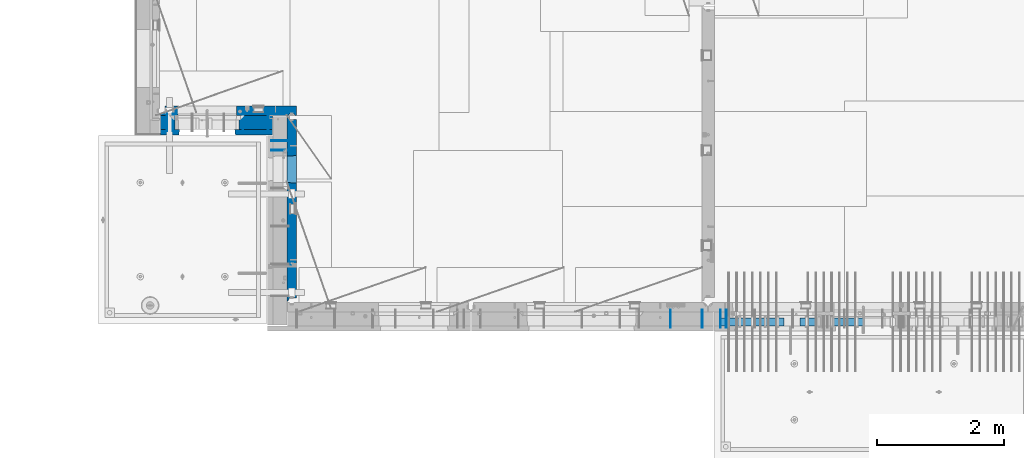
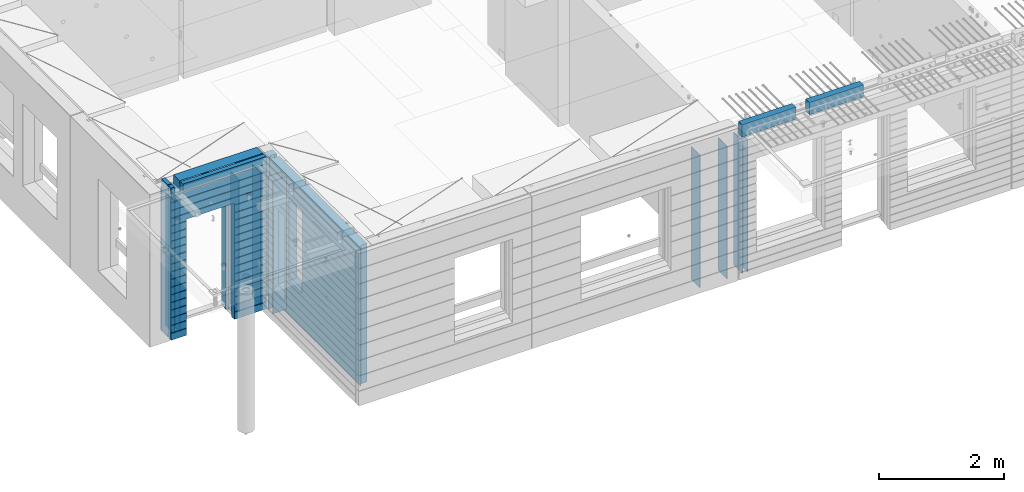
# One storey, part 228 of 349: 16 walls, 7 elements without a shape of their own.
"""IFC2X3 building model written with IfcOpenShell, lengths in millimetres."""

from ifc_helpers import new_model, si_unit, frame, origin_with_axes, place, context, subcontext, project, spatial, faceted_brep, material, type_object, element, aggregate, save


model = new_model("IFC2X3")

# Units and contexts
model_context = context("Model", 3, precision=1e-05, world=origin_with_axes())
body_context = subcontext(model_context, "Body", "Model", "MODEL_VIEW")
ifc_project = project(units=[si_unit("LENGTHUNIT", "METRE", prefix="MILLI"), si_unit("AREAUNIT", "SQUARE_METRE"), si_unit("VOLUMEUNIT", "CUBIC_METRE"), si_unit("MASSUNIT", "GRAM", prefix="KILO"), si_unit("TIMEUNIT", "SECOND"), si_unit("PLANEANGLEUNIT", "RADIAN"), si_unit("SOLIDANGLEUNIT", "STERADIAN"), si_unit("THERMODYNAMICTEMPERATUREUNIT", "DEGREE_CELSIUS"), si_unit("LUMINOUSINTENSITYUNIT", "LUMEN")], contexts=[model_context])

# Site, building, storey
site_placement = place(None, origin_with_axes())
site = spatial("IfcSite", under=ifc_project, at=site_placement, CompositionType="ELEMENT")
building_placement = place(site_placement, origin_with_axes())
building = spatial("IfcBuilding", under=site, at=building_placement, CompositionType="ELEMENT")
storey_placement = place(building_placement, origin_with_axes())
storey = spatial("IfcBuildingStorey", under=building, at=storey_placement, Name="4", CompositionType="ELEMENT", Elevation=0.0)

# Assembly, wall
assembly_1_placement = place(storey_placement, origin_with_axes())
assembly_1 = element("IfcElementAssembly", 1, at=assembly_1_placement, inside=storey, AssemblyPlace="NOTDEFINED", PredefinedType="REINFORCEMENT_UNIT")
ifc_material_1 = material(Name="Undefined")
wall_type_1 = type_object("IfcWallType", PredefinedType="NOTDEFINED")
wall_1_placement = place(assembly_1_placement, frame((16855.0, 7880.0, 92115.0), z_axis=(0.0, 0.0, 1.0), x_axis=(0.0, -1.0, 0.0)))
wall_1 = element("IfcWall", 2, at=wall_1_placement, type_object=wall_type_1, material=ifc_material_1, Name="(PD)", context=body_context, shape_type="Brep", body=[
    faceted_brep([(0.0, 5.0, -1300.0), (0.0, 5.0, 1300.0), (280.0, 5.0, 1300.0), (280.0, 5.0, -1300.0), (0.0, -5.0, 1300.0), (280.0, -5.0, 1300.0), (0.0, -5.0, -1300.0), (280.0, -5.0, -1300.0)], [[[0, 1, 2, 3]], [[1, 4, 5, 2]], [[4, 6, 7, 5]], [[6, 0, 3, 7]], [[5, 7, 3, 2]], [[6, 4, 1, 0]]]),
])

# Assembly, walls
assembly_2_placement = place(storey_placement, origin_with_axes())
assembly_2 = element("IfcElementAssembly", 3, at=assembly_2_placement, inside=storey, AssemblyPlace="NOTDEFINED", PredefinedType="REINFORCEMENT_UNIT")
wall_2_placement = place(assembly_2_placement, frame((16565.0, 7880.0, 92115.0), z_axis=(0.0, 0.0, 1.0), x_axis=(0.0, -1.0, 0.0)))
wall_2 = element("IfcWall", 4, at=wall_2_placement, type_object=wall_type_1, material=ifc_material_1, Name="(PD)", context=body_context, shape_type="Brep", body=[
    faceted_brep([(0.0, 5.0, -1300.0), (0.0, 5.0, 1300.0), (280.0, 5.0, 1300.0), (280.0, 5.0, -1300.0), (0.0, -5.0, 1300.0), (280.0, -5.0, 1300.0), (0.0, -5.0, -1300.0), (280.0, -5.0, -1300.0)], [[[0, 1, 2, 3]], [[1, 4, 5, 2]], [[4, 6, 7, 5]], [[6, 0, 3, 7]], [[5, 7, 3, 2]], [[6, 4, 1, 0]]]),
])
wall_3_placement = place(assembly_2_placement, frame((16065.0, 7880.0, 92115.0), z_axis=(0.0, 0.0, 1.0), x_axis=(0.0, -1.0, 0.0)))
wall_3 = element("IfcWall", 5, at=wall_3_placement, type_object=wall_type_1, material=ifc_material_1, Name="(PD)", context=body_context, shape_type="Brep", body=[
    faceted_brep([(0.0, 5.0, -1300.0), (0.0, 5.0, 1300.0), (280.0, 5.0, 1300.0), (280.0, 5.0, -1300.0), (0.0, -5.0, 1300.0), (280.0, -5.0, 1300.0), (0.0, -5.0, -1300.0), (280.0, -5.0, -1300.0)], [[[0, 1, 2, 3]], [[1, 4, 5, 2]], [[4, 6, 7, 5]], [[6, 0, 3, 7]], [[5, 7, 3, 2]], [[6, 4, 1, 0]]]),
])
aggregate(assembly_2, [wall_2, wall_3])

# Assembly, wall
assembly_3_placement = place(storey_placement, origin_with_axes())
assembly_3 = element("IfcElementAssembly", 6, at=assembly_3_placement, inside=storey, AssemblyPlace="NOTDEFINED", PredefinedType="REINFORCEMENT_UNIT")
wall_4_placement = place(assembly_3_placement, frame((8215.0, 10980.0, 92115.0), z_axis=(0.0, 0.0, 1.0), x_axis=(0.0, -1.0, 0.0)))
wall_4 = element("IfcWall", 7, at=wall_4_placement, type_object=wall_type_1, material=ifc_material_1, Name="(PD)", context=body_context, shape_type="Brep", body=[
    faceted_brep([(0.0, 5.0, -1300.0), (0.0, 5.0, 1300.0), (280.0, 5.0, 1300.0), (280.0, 5.0, -1300.0), (0.0, -5.0, 1300.0), (280.0, -5.0, 1300.0), (0.0, -5.0, -1300.0), (280.0, -5.0, -1300.0)], [[[0, 1, 2, 3]], [[1, 4, 5, 2]], [[4, 6, 7, 5]], [[6, 0, 3, 7]], [[5, 7, 3, 2]], [[6, 4, 1, 0]]]),
])

# Wall
wall_5_placement = place(assembly_1_placement, frame((16945.0, 7880.0, 92115.0), z_axis=(0.0, 0.0, 1.0), x_axis=(0.0, -1.0, 0.0)))
wall_5 = element("IfcWall", 8, at=wall_5_placement, type_object=wall_type_1, material=ifc_material_1, Name="(PD)", context=body_context, shape_type="Brep", body=[
    faceted_brep([(0.0, 5.0, -1300.0), (0.0, 5.0, 1300.0), (280.0, 5.0, 1300.0), (280.0, 5.0, -1300.0), (0.0, -5.0, 1300.0), (280.0, -5.0, 1300.0), (0.0, -5.0, -1300.0), (280.0, -5.0, -1300.0)], [[[0, 1, 2, 3]], [[1, 4, 5, 2]], [[4, 6, 7, 5]], [[6, 0, 3, 7]], [[5, 7, 3, 2]], [[6, 4, 1, 0]]]),
])

aggregate(assembly_1, [wall_1, wall_5])

wall_6_placement = place(assembly_3_placement, frame((8115.0, 10980.0, 92115.0), z_axis=(0.0, 0.0, 1.0), x_axis=(0.0, -1.0, 0.0)))
wall_6 = element("IfcWall", 9, at=wall_6_placement, type_object=wall_type_1, material=ifc_material_1, Name="(PD)", context=body_context, shape_type="Brep", body=[
    faceted_brep([(0.0, 5.0, -1300.0), (0.0, 5.0, 1300.0), (280.0, 5.0, 1300.0), (280.0, 5.0, -1300.0), (0.0, -5.0, 1300.0), (280.0, -5.0, 1300.0), (0.0, -5.0, -1300.0), (280.0, -5.0, -1300.0)], [[[0, 1, 2, 3]], [[1, 4, 5, 2]], [[4, 6, 7, 5]], [[6, 0, 3, 7]], [[5, 7, 3, 2]], [[6, 4, 1, 0]]]),
])

wall_7_placement = place(assembly_3_placement, frame((9315.0, 10980.0, 92115.0), z_axis=(0.0, 0.0, 1.0), x_axis=(0.0, -1.0, 0.0)))
wall_7 = element("IfcWall", 10, at=wall_7_placement, type_object=wall_type_1, material=ifc_material_1, Name="(PD)", context=body_context, shape_type="Brep", body=[
    faceted_brep([(0.0, 5.0, -1300.0), (0.0, 5.0, 1300.0), (280.0, 5.0, 1300.0), (280.0, 5.0, -1300.0), (0.0, -5.0, 1300.0), (280.0, -5.0, 1300.0), (0.0, -5.0, -1300.0), (280.0, -5.0, -1300.0)], [[[0, 1, 2, 3]], [[1, 4, 5, 2]], [[4, 6, 7, 5]], [[6, 0, 3, 7]], [[5, 7, 3, 2]], [[6, 4, 1, 0]]]),
])

wall_8_placement = place(assembly_3_placement, frame((9715.0, 10980.0, 92115.0), z_axis=(0.0, 0.0, 1.0), x_axis=(0.0, -1.0, 0.0)))
wall_8 = element("IfcWall", 11, at=wall_8_placement, type_object=wall_type_1, material=ifc_material_1, Name="(PD)", context=body_context, shape_type="Brep", body=[
    faceted_brep([(0.0, 5.0, -1300.0), (0.0, 5.0, 1300.0), (280.0, 5.0, 1300.0), (280.0, 5.0, -1300.0), (0.0, -5.0, 1300.0), (280.0, -5.0, 1300.0), (0.0, -5.0, -1300.0), (280.0, -5.0, -1300.0)], [[[0, 1, 2, 3]], [[1, 4, 5, 2]], [[4, 6, 7, 5]], [[6, 0, 3, 7]], [[5, 7, 3, 2]], [[6, 4, 1, 0]]]),
])

# Assembly, walls
assembly_4_placement = place(storey_placement, origin_with_axes())
assembly_4 = element("IfcElementAssembly", 12, at=assembly_4_placement, inside=storey, AssemblyPlace="NOTDEFINED", PredefinedType="REINFORCEMENT_UNIT")
wall_9_placement = place(assembly_4_placement, frame((10040.0, 10400.0, 92115.0), z_axis=(0.0, 0.0, 1.0), x_axis=(-1.0, 3.00000001838171e-08, 0.0)))
wall_9 = element("IfcWall", 13, at=wall_9_placement, type_object=wall_type_1, material=ifc_material_1, Name="(PD)", context=body_context, shape_type="Brep", body=[
    faceted_brep([(0.0, 5.0, -1300.0), (0.0, 5.0, 1300.0), (280.0, 5.0, 1300.0), (280.0, 5.0, -1300.0), (0.0, -5.0, 1300.0), (280.0, -5.0, 1300.0), (0.0, -5.0, -1300.0), (280.0, -5.0, -1300.0)], [[[0, 1, 2, 3]], [[1, 4, 5, 2]], [[4, 6, 7, 5]], [[6, 0, 3, 7]], [[5, 7, 3, 2]], [[6, 4, 1, 0]]]),
])
wall_10_placement = place(assembly_4_placement, frame((10040.0, 10550.0, 92115.0), z_axis=(0.0, 0.0, 1.0), x_axis=(-1.0, 3.00000001838171e-08, 0.0)))
wall_10 = element("IfcWall", 14, at=wall_10_placement, type_object=wall_type_1, material=ifc_material_1, Name="(PD)", context=body_context, shape_type="Brep", body=[
    faceted_brep([(0.0, 5.0, -1300.0), (0.0, 5.0, 1300.0), (280.0, 5.0, 1300.0), (280.0, 5.0, -1300.0), (0.0, -5.0, 1300.0), (280.0, -5.0, 1300.0), (0.0, -5.0, -1300.0), (280.0, -5.0, -1300.0)], [[[0, 1, 2, 3]], [[1, 4, 5, 2]], [[4, 6, 7, 5]], [[6, 0, 3, 7]], [[5, 7, 3, 2]], [[6, 4, 1, 0]]]),
])

# Assemblies, walls
assembly_5_placement = place(storey_placement, origin_with_axes())
assembly_5 = element("IfcElementAssembly", 15, at=assembly_5_placement, inside=storey, AssemblyPlace="NOTDEFINED", PredefinedType="REINFORCEMENT_UNIT")
assembly_6_placement = place(assembly_5_placement, origin_with_axes())
assembly_6 = element("IfcElementAssembly", 16, at=assembly_6_placement, Name="Steel Assembly", AssemblyPlace="NOTDEFINED", PredefinedType="NOTDEFINED")
ifc_material_2 = material()
wall_type_2 = type_object("IfcWallType", PredefinedType="NOTDEFINED")
wall_11_placement = place(assembly_6_placement, frame((16859.9998568133, 7690.00021946163, 93590.0), z_axis=(0.0, 0.0, 1.0), x_axis=(1.0, 0.0, 0.0)))
wall_11 = element("IfcWall", 17, at=wall_11_placement, type_object=wall_type_2, material=ifc_material_2, context=body_context, shape_type="Brep", body=[
    faceted_brep([(0.0, 60.0, -120.0), (0.0, 60.0, 120.0), (1000.0, 60.0, 120.0), (1000.0, 60.0, -120.0), (0.0, -60.0, 120.0), (1000.0, -60.0, 120.0), (0.0, -60.0, -120.0), (1000.0, -60.0, -120.0)], [[[0, 1, 2, 3]], [[1, 4, 5, 2]], [[4, 6, 7, 5]], [[6, 0, 3, 7]], [[5, 7, 3, 2]], [[6, 4, 1, 0]]]),
])
aggregate(assembly_6, [wall_11])
assembly_7_placement = place(assembly_5_placement, origin_with_axes())
assembly_7 = element("IfcElementAssembly", 18, at=assembly_7_placement, Name="Steel Assembly", AssemblyPlace="NOTDEFINED", PredefinedType="NOTDEFINED")
aggregate(assembly_5, [assembly_7, assembly_6])
wall_12_placement = place(assembly_7_placement, frame((18109.9998568133, 7690.00021946163, 93590.0), z_axis=(0.0, 0.0, 1.0), x_axis=(1.0, 0.0, 0.0)))
wall_12 = element("IfcWall", 19, at=wall_12_placement, type_object=wall_type_2, material=ifc_material_2, context=body_context, shape_type="Brep", body=[
    faceted_brep([(0.0, 60.0, -120.0), (0.0, 60.0, 120.0), (1000.0, 60.0, 120.0), (1000.0, 60.0, -120.0), (0.0, -60.0, 120.0), (1000.0, -60.0, 120.0), (0.0, -60.0, -120.0), (1000.0, -60.0, -120.0)], [[[0, 1, 2, 3]], [[1, 4, 5, 2]], [[4, 6, 7, 5]], [[6, 0, 3, 7]], [[5, 7, 3, 2]], [[6, 4, 1, 0]]]),
])
aggregate(assembly_7, [wall_12])

# Wall
ifc_material_3 = material(Name="COS5gt")
wall_type_3 = type_object("IfcWallType", PredefinedType="NOTDEFINED")
wall_13_placement = place(assembly_3_placement, frame((9784.0, 10840.0, 92247.5), z_axis=(0.0, 0.0, 1.0), x_axis=(-1.0, 3.00000001838171e-08, 0.0)))
wall_13 = element("IfcWall", 20, at=wall_13_placement, type_object=wall_type_3, material=ifc_material_3, context=body_context, shape_type="Brep", body=[
    faceted_brep([(1699.0, -110.0, 1492.5), (1699.0, 90.0, 1492.5), (1699.0, 90.0, 1442.5), (1699.0, 110.0, 1442.5), (1699.0, 110.0, 1222.5), (1699.0, -110.0, 1222.5), (1549.0, 110.0, 1222.5), (1549.0, -110.0, 1222.5), (1549.0, -110.0, 1492.5), (1549.0, 110.0, 1442.5), (1549.0, 90.0, 1442.5), (1549.0, 90.0, 1492.5), (0.0, -110.0, -1492.5), (0.0, 90.0, -1492.5), (529.001442432404, 90.0, -1492.5), (529.001442432404, -110.0, -1492.5), (0.0, 90.0, -1442.5), (0.0, 110.0, -1442.5), (529.001442432404, 110.0, -1442.5), (529.001442432404, 90.0, -1442.5), (1769.0, 90.0, -1442.5), (1769.0, 90.0, -1492.5), (1539.0014424324, 90.0, -1492.5), (1539.0014424324, 90.0, -1442.5), (1769.0, 110.0, -1442.5), (1539.0014424324, 110.0, -1442.5), (1769.0, 110.0, 1442.5), (1769.0, 90.0, 1442.5), (1769.0, 90.0, 1492.5), (1769.0, -110.0, 1492.5), (1769.0, -110.0, -1492.5), (1539.0014424324, -110.0, -1492.5), (1539.0014424324, -110.0, 847.5), (1539.0014424324, 110.0, 847.5), (529.001442432404, -110.0, 847.5), (529.001442432404, 110.0, 847.5), (0.0, -110.0, 1492.5), (0.0, 90.0, 1492.5), (0.0, 90.0, 1442.5), (0.0, 110.0, 1442.5)], [[[0, 1, 2, 3, 4, 5]], [[5, 4, 6, 7]], [[8, 7, 6, 9, 10, 11]], [[12, 13, 14, 15]], [[16, 17, 18, 19]], [[20, 21, 22, 23]], [[24, 20, 23, 25]], [[26, 27, 28, 29, 30, 21, 20, 24]], [[21, 30, 31, 22]], [[32, 33, 25, 23, 22, 31]], [[34, 35, 33, 32]], [[15, 14, 19, 18, 35, 34]], [[13, 16, 19, 14]], [[13, 12, 36, 37, 38, 39, 17, 16]], [[37, 36, 8, 11]], [[38, 37, 11, 10]], [[39, 38, 10, 9]], [[4, 3, 26, 24, 25, 33, 35, 18, 17, 39, 9, 6]], [[27, 26, 3, 2]], [[28, 27, 2, 1]], [[29, 28, 1, 0]], [[36, 12, 15, 34, 32, 31, 30, 29, 0, 5, 7, 8]]]),
])

ifc_material_4 = material(Name="CONCRETE/C30/37")
wall_type_4 = type_object("IfcWallType", PredefinedType="NOTDEFINED")
wall_14_placement = place(assembly_3_placement, frame((9784.0, 10687.5, 92247.5), z_axis=(0.0, 0.0, 1.0), x_axis=(-1.0, 3.00000001838171e-08, 0.0)))
wall_14 = element("IfcWall", 21, at=wall_14_placement, type_object=wall_type_4, material=ifc_material_4, context=body_context, shape_type="Brep", body=[
    faceted_brep([(1699.0, -42.5, 1492.5), (1699.0, 42.5, 1492.5), (1699.0, 42.5, 1356.99999988925), (1699.0, 32.4999991126988, 1355.00000040044), (1699.0, 32.4999992506928, 1344.99999999921), (1699.0, 42.5, 1342.99999994476), (1699.0, 42.5, 1222.5), (1699.0, -42.5, 1222.5), (1549.0, 42.5, 1222.5), (1549.0, -42.5, 1222.5), (1549.0, -42.5, 1492.5), (1549.0, 42.5, 1342.99999994476), (1549.0, 32.4999992506928, 1344.99999999921), (1549.0, 32.4999991126988, 1355.00000040044), (1549.0, 42.5, 1356.99999988925), (1549.0, 42.5, 1492.5), (1478.99938360887, 42.5, 606.999999889245), (1769.0, 42.5, 606.999999889245), (1769.0, 32.4999991126988, 605.00000040044), (1477.8227168378, 32.4999991126988, 605.00000040044), (1769.0, 32.4999992506928, 594.999999999214), (1477.82271685404, 32.4999992506928, 594.999999999214), (1769.0, 42.5, 592.999999944761), (1478.99938360887, 42.5, 592.999999944761), (1769.0, 42.5, 456.999999889245), (1478.99938360887, 42.5, 456.999999889245), (1769.0, 32.4999991126988, 455.00000040044), (1477.8227168378, 32.4999991126988, 455.00000040044), (1769.0, 32.4999992506928, 444.999999999214), (1477.82271685404, 32.4999992506928, 444.999999999214), (1769.0, 42.5, 442.999999944761), (1478.99938360887, 42.5, 442.999999944761), (1769.0, 42.5, 306.999999889245), (1478.99938360887, 42.5, 306.999999889245), (1769.0, 32.4999991126988, 305.00000040044), (1477.8227168378, 32.4999991126988, 305.00000040044), (1769.0, 32.4999992506928, 294.999999999214), (1477.82271685404, 32.4999992506928, 294.999999999214), (1769.0, 42.5, 292.999999944761), (1478.99938360887, 42.5, 292.999999944761), (1769.0, 42.5, 156.999999889245), (1478.99938360887, 42.5, 156.999999889245), (1769.0, 32.4999991126988, 155.00000040044), (1477.8227168378, 32.4999991126988, 155.00000040044), (1769.0, 32.4999992506928, 144.999999999214), (1477.82271685404, 32.4999992506928, 144.999999999214), (1769.0, 42.5, 142.999999944761), (1478.99938360887, 42.5, 142.999999944761), (1769.0, 42.5, 6.99999988924537), (1478.99938360887, 42.5, 6.99999988924537), (1769.0, 32.4999991126988, 5.0000004004396), (1477.8227168378, 32.4999991126988, 5.0000004004396), (1769.0, 32.4999992506928, -5.0000000007858), (1477.82271685404, 32.4999992506928, -5.0000000007858), (1769.0, 42.5, -7.00000005523907), (1478.99938360887, 42.5, -7.00000005523907), (1769.0, 42.5, -143.000000110755), (1478.99938360887, 42.5, -143.000000110755), (1769.0, 32.4999991126988, -144.99999959956), (1477.8227168378, 32.4999991126988, -144.99999959956), (1769.0, 32.4999992506928, -155.000000000786), (1477.82271685404, 32.4999992506928, -155.000000000786), (1769.0, 42.5, -157.000000055239), (1478.99938360887, 42.5, -157.000000055239), (1769.0, 42.5, -293.000000110755), (1478.99938360887, 42.5, -293.000000110755), (1769.0, 32.4999991126988, -294.99999959956), (1477.8227168378, 32.4999991126988, -294.99999959956), (1769.0, 32.4999992506928, -305.000000000786), (1477.82271685404, 32.4999992506928, -305.000000000786), (1769.0, 42.5, -307.000000055239), (1478.99938360887, 42.5, -307.000000055239), (1769.0, 42.5, -443.000000110755), (1478.99938360887, 42.5, -443.000000110755), (1769.0, 32.4999991126988, -444.99999959956), (1477.8227168378, 32.4999991126988, -444.99999959956), (1769.0, 32.4999992506928, -455.000000000786), (1477.82271685404, 32.4999992506928, -455.000000000786), (1769.0, 42.5, -457.000000055239), (1478.99938360887, 42.5, -457.000000055239), (1769.0, 42.5, -593.000000110755), (1478.99938360887, 42.5, -593.000000110755), (1769.0, 32.4999991126988, -594.99999959956), (1477.8227168378, 32.4999991126988, -594.99999959956), (1769.0, 32.4999992506928, -605.000000000786), (1477.82271685404, 32.4999992506928, -605.000000000786), (1769.0, 42.5, -607.000000055239), (1478.99938360887, 42.5, -607.000000055239), (1769.0, 42.5, -743.000000110755), (1478.99938360887, 42.5, -743.000000110755), (1769.0, 32.4999991126988, -744.99999959956), (1477.8227168378, 32.4999991126988, -744.99999959956), (1769.0, 32.4999992506928, -755.000000000786), (1477.82271685404, 32.4999992506928, -755.000000000786), (1769.0, 42.5, -757.000000055239), (1478.99938360887, 42.5, -757.000000055239), (1769.0, 42.5, -893.000000110755), (1478.99938360887, 42.5, -893.000000110755), (1769.0, 32.4999991126988, -894.99999959956), (1477.8227168378, 32.4999991126988, -894.99999959956), (1769.0, 32.4999992506928, -905.000000000786), (1477.82271685404, 32.4999992506928, -905.000000000786), (1769.0, 42.5, -907.000000055239), (1478.99938360887, 42.5, -907.000000055239), (1769.0, 42.5, -1043.00000011075), (1478.99938360887, 42.5, -1043.00000011075), (1769.0, 32.4999991126988, -1044.99999959956), (1477.8227168378, 32.4999991126988, -1044.99999959956), (1769.0, 32.4999992506928, -1055.00000000079), (1477.82271685404, 32.4999992506928, -1055.00000000079), (1769.0, 42.5, -1057.00000005524), (1478.99938360887, 42.5, -1057.00000005524), (1769.0, 42.5, -1193.00000011075), (1478.99938360887, 42.5, -1193.00000011075), (1769.0, 32.4999991126988, -1194.99999959956), (1477.8227168378, 32.4999991126988, -1194.99999959956), (1769.0, 32.4999992506928, -1205.00000000079), (1477.82271685404, 32.4999992506928, -1205.00000000079), (1769.0, 42.5, -1207.00000005524), (1478.99938360887, 42.5, -1207.00000005524), (1769.0, 42.5, -1343.00000011075), (1478.99938360887, 42.5, -1343.00000011075), (1769.0, 32.4999991126988, -1344.99999959956), (1477.8227168378, 32.4999991126988, -1344.99999959956), (1769.0, 32.4999992506928, -1355.00000000079), (1477.82271685404, 32.4999992506928, -1355.00000000079), (1769.0, 42.5, -1357.00000005524), (1478.99938360887, 42.5, -1357.00000005524), (1769.0, 42.5, -1492.5), (1478.99938360887, 42.5, -1492.5), (1769.0, -42.5, -1492.5), (1468.99771694221, -42.5, -1492.5), (599.001442432404, 42.5, 782.5), (1469.0014424324, 42.5, 782.5), (1478.99938360887, 42.5, 782.5), (1468.99771694221, -42.5, 787.502857142856), (599.001050275541, -42.5, 787.502857142856), (588.999383608874, 42.5, 782.5), (1478.99938360887, 42.5, 742.999999944761), (1468.99771694221, -42.5, 782.5), (1478.99938360887, 42.5, 756.999999889245), (1477.82271683781, 32.4999991126988, 755.00000040044), (1477.82271685404, 32.4999992506928, 744.999999999214), (1769.0, 42.5, 742.999999944761), (1769.0, 32.4999992506928, 744.999999999214), (1769.0, 32.4999991126988, 755.00000040044), (1769.0, 42.5, 756.999999889245), (0.0, 32.4999991127006, 905.00000040044), (1769.0, 32.4999991126988, 905.00000040044), (1769.0, 32.4999992506928, 894.999999999214), (0.0, 32.4999992507037, 894.999999999258), (0.0, 42.5, 906.999999889245), (1769.0, 42.5, 906.999999889245), (0.0, 42.5, 1042.99999994476), (1769.0, 42.5, 1042.99999994476), (0.0, 32.4999992507037, 1044.99999999926), (1769.0, 32.4999992506928, 1044.99999999921), (0.0, 32.4999991127006, 1055.00000040044), (1769.0, 32.4999991126988, 1055.00000040044), (0.0, 42.5, 1056.99999988925), (1769.0, 42.5, 1056.99999988925), (0.0, 42.5, 1192.99999994476), (1769.0, 42.5, 1192.99999994476), (0.0, 32.4999992507037, 1194.99999999926), (1769.0, 32.4999992506928, 1194.99999999921), (0.0, 32.4999991127006, 1205.00000040044), (1769.0, 32.4999991126988, 1205.00000040044), (0.0, 42.5, 1206.99999988925), (1769.0, 42.5, 1206.99999988925), (1769.0, 42.5, 1492.5), (1769.0, -42.5, 1492.5), (1769.0, 42.5, 892.999999944761), (1769.0, 42.5, 1342.99999994476), (1769.0, 32.4999992506928, 1344.99999999921), (1769.0, 32.4999991126988, 1355.00000040044), (1769.0, 42.5, 1356.99999988925), (0.0, 42.5, 892.999999944761), (588.999383608874, 42.5, 756.999999889245), (0.0, 42.5, 756.999999889245), (588.999383608874, 42.5, -1492.5), (0.0, 42.5, -1492.5), (0.0, 42.5, -1357.00000005524), (588.999383608874, 42.5, -1357.00000005524), (0.0, 32.4999992507037, -1355.00000000074), (590.176050363707, 32.4999992506928, -1355.00000000079), (0.0, 32.4999991127006, -1344.99999959956), (590.176050379945, 32.4999991126988, -1344.99999959956), (0.0, 42.5, -1343.00000011075), (588.999383608874, 42.5, -1343.00000011075), (0.0, 42.5, -1207.00000005524), (588.999383608874, 42.5, -1207.00000005524), (0.0, 32.4999992507037, -1205.00000000074), (590.176050363709, 32.4999992506928, -1205.00000000079), (0.0, 32.4999991127006, -1194.99999959956), (590.176050379947, 32.4999991126988, -1194.99999959956), (0.0, 42.5, -1193.00000011075), (588.999383608874, 42.5, -1193.00000011075), (0.0, 42.5, -1057.00000005524), (588.999383608874, 42.5, -1057.00000005524), (0.0, 32.4999992507037, -1055.00000000074), (590.176050363711, 32.4999992506928, -1055.00000000079), (0.0, 32.4999991127006, -1044.99999959956), (590.176050379947, 32.4999991126988, -1044.99999959956), (0.0, 42.5, -1043.00000011075), (588.999383608874, 42.5, -1043.00000011075), (0.0, 42.5, -907.000000055239), (588.999383608874, 42.5, -907.000000055239), (0.0, 32.4999992507037, -905.000000000742), (590.176050363711, 32.4999992506928, -905.000000000786), (0.0, 32.4999991127006, -894.99999959956), (590.176050379947, 32.4999991126988, -894.99999959956), (0.0, 42.5, -893.000000110755), (588.999383608874, 42.5, -893.000000110755), (0.0, 42.5, -757.000000055239), (588.999383608874, 42.5, -757.000000055239), (0.0, 32.4999992507037, -755.000000000742), (590.176050363711, 32.4999992506928, -755.000000000786), (0.0, 32.4999991127006, -744.99999959956), (590.176050379947, 32.4999991126988, -744.99999959956), (0.0, 42.5, -743.000000110755), (588.999383608874, 42.5, -743.000000110755), (0.0, 42.5, -607.000000055239), (588.999383608874, 42.5, -607.000000055239), (3.63797880709171e-12, 32.4999992507037, -605.000000000742), (590.176050363709, 32.4999992506928, -605.000000000786), (3.63797880709171e-12, 32.4999991127006, -594.99999959956), (590.176050379947, 32.4999991126988, -594.99999959956), (0.0, 42.5, -593.000000110755), (588.999383608874, 42.5, -593.000000110755), (0.0, 42.5, -457.000000055239), (588.999383608874, 42.5, -457.000000055239), (0.0, 32.4999992507037, -455.000000000742), (590.176050363711, 32.4999992506928, -455.000000000786), (0.0, 32.4999991127006, -444.99999959956), (590.176050379947, 32.4999991126988, -444.99999959956), (0.0, 42.5, -443.000000110755), (588.999383608874, 42.5, -443.000000110755), (0.0, 42.5, -307.000000055239), (588.999383608874, 42.5, -307.000000055239), (0.0, 32.4999992507037, -305.000000000742), (590.176050363711, 32.4999992506928, -305.000000000786), (0.0, 32.4999991127006, -294.99999959956), (590.176050379947, 32.4999991126988, -294.99999959956), (0.0, 42.5, -293.000000110755), (588.999383608874, 42.5, -293.000000110755), (0.0, 42.5, -157.000000055239), (588.999383608874, 42.5, -157.000000055239), (3.63797880709171e-12, 32.4999992507037, -155.000000000742), (590.176050363707, 32.4999992506928, -155.000000000786), (3.63797880709171e-12, 32.4999991127006, -144.99999959956), (590.176050379945, 32.4999991126988, -144.99999959956), (0.0, 42.5, -143.000000110755), (588.999383608874, 42.5, -143.000000110755), (0.0, 42.5, -7.00000005523907), (588.999383608874, 42.5, -7.00000005523907), (0.0, 32.4999992507037, -5.00000000074215), (590.176050363705, 32.4999992506928, -5.0000000007858), (0.0, 32.4999991127006, 5.0000004004396), (590.176050379941, 32.4999991126988, 5.0000004004396), (0.0, 42.5, 6.99999988924537), (588.999383608874, 42.5, 6.99999988924537), (0.0, 42.5, 142.999999944761), (588.999383608874, 42.5, 142.999999944761), (-3.63797880709171e-12, 32.4999992507037, 144.999999999258), (590.176050363705, 32.4999992506928, 144.999999999214), (-3.63797880709171e-12, 32.4999991127006, 155.00000040044), (590.176050379943, 32.4999991126988, 155.00000040044), (0.0, 42.5, 156.999999889245), (588.999383608874, 42.5, 156.999999889245), (0.0, 42.5, 292.999999944761), (588.999383608874, 42.5, 292.999999944761), (-3.63797880709171e-12, 32.4999992507037, 294.999999999258), (590.176050363703, 32.4999992506928, 294.999999999214), (-3.63797880709171e-12, 32.4999991127006, 305.00000040044), (590.17605037994, 32.4999991126988, 305.00000040044), (0.0, 42.5, 306.999999889245), (588.999383608874, 42.5, 306.999999889245), (0.0, 42.5, 442.999999944761), (588.999383608874, 42.5, 442.999999944761), (0.0, 32.4999992507037, 444.999999999258), (590.176050363702, 32.4999992506928, 444.999999999214), (0.0, 32.4999991127006, 455.00000040044), (590.176050379938, 32.4999991126988, 455.00000040044), (0.0, 42.5, 456.999999889245), (588.999383608874, 42.5, 456.999999889245), (0.0, 42.5, 592.999999944761), (588.999383608874, 42.5, 592.999999944761), (3.63797880709171e-12, 32.4999992507037, 594.999999999258), (590.176050363702, 32.4999992506928, 594.999999999214), (3.63797880709171e-12, 32.4999991127006, 605.00000040044), (590.17605037994, 32.4999991126988, 605.00000040044), (0.0, 42.5, 606.999999889245), (588.999383608874, 42.5, 606.999999889245), (0.0, 42.5, 742.999999944761), (588.999383608874, 42.5, 742.999999944761), (0.0, 32.4999992507037, 744.999999999258), (590.176050363705, 32.4999992506928, 744.999999999214), (0.0, 32.4999991127006, 755.00000040044), (590.176050379943, 32.4999991126988, 755.00000040044), (599.001050275541, -42.5, 782.5), (599.001050275539, -42.5, -1492.5), (0.0, -42.5, -1492.5), (-3.63797880709171e-12, 32.4999992507037, 1344.99999999926), (0.0, 42.5, 1342.99999994476), (0.0, -42.5, 1492.5), (0.0, 42.5, 1492.5), (0.0, 42.5, 1356.99999988925), (-3.63797880709171e-12, 32.4999991127006, 1355.00000040044)], [[[0, 1, 2, 3, 4, 5, 6, 7]], [[7, 6, 8, 9]], [[10, 9, 8, 11, 12, 13, 14, 15]], [[16, 17, 18, 19]], [[19, 18, 20, 21]], [[21, 20, 22, 23]], [[24, 25, 23, 22]], [[25, 24, 26, 27]], [[27, 26, 28, 29]], [[29, 28, 30, 31]], [[32, 33, 31, 30]], [[33, 32, 34, 35]], [[35, 34, 36, 37]], [[37, 36, 38, 39]], [[40, 41, 39, 38]], [[41, 40, 42, 43]], [[43, 42, 44, 45]], [[45, 44, 46, 47]], [[48, 49, 47, 46]], [[49, 48, 50, 51]], [[51, 50, 52, 53]], [[53, 52, 54, 55]], [[56, 57, 55, 54]], [[57, 56, 58, 59]], [[59, 58, 60, 61]], [[61, 60, 62, 63]], [[64, 65, 63, 62]], [[65, 64, 66, 67]], [[67, 66, 68, 69]], [[69, 68, 70, 71]], [[72, 73, 71, 70]], [[73, 72, 74, 75]], [[75, 74, 76, 77]], [[77, 76, 78, 79]], [[80, 81, 79, 78]], [[81, 80, 82, 83]], [[83, 82, 84, 85]], [[85, 84, 86, 87]], [[88, 89, 87, 86]], [[89, 88, 90, 91]], [[91, 90, 92, 93]], [[93, 92, 94, 95]], [[96, 97, 95, 94]], [[97, 96, 98, 99]], [[99, 98, 100, 101]], [[101, 100, 102, 103]], [[104, 105, 103, 102]], [[105, 104, 106, 107]], [[107, 106, 108, 109]], [[109, 108, 110, 111]], [[112, 113, 111, 110]], [[113, 112, 114, 115]], [[115, 114, 116, 117]], [[117, 116, 118, 119]], [[120, 121, 119, 118]], [[121, 120, 122, 123]], [[123, 122, 124, 125]], [[125, 124, 126, 127]], [[128, 129, 127, 126]], [[128, 130, 131, 129]], [[132, 133, 134, 135, 136, 137]], [[138, 16, 19, 21, 23, 25, 27, 29, 31, 33, 35, 37, 39, 41, 43, 45, 47, 49, 51, 53, 55, 57, 59, 61, 63, 65, 67, 69, 71, 73, 75, 77, 79, 81, 83, 85, 87, 89, 91, 93, 95, 97, 99, 101, 103, 105, 107, 109, 111, 113, 115, 117, 119, 121, 123, 125, 127, 129, 131, 139, 135, 134, 140, 141, 142]], [[17, 16, 138, 143]], [[142, 144, 143, 138]], [[141, 145, 144, 142]], [[140, 146, 145, 141]], [[147, 148, 149, 150]], [[151, 152, 148, 147]], [[152, 151, 153, 154]], [[155, 156, 154, 153]], [[157, 158, 156, 155]], [[159, 160, 158, 157]], [[160, 159, 161, 162]], [[163, 164, 162, 161]], [[165, 166, 164, 163]], [[167, 168, 166, 165]], [[169, 170, 130, 128, 126, 124, 122, 120, 118, 116, 114, 112, 110, 108, 106, 104, 102, 100, 98, 96, 94, 92, 90, 88, 86, 84, 82, 80, 78, 76, 74, 72, 70, 68, 66, 64, 62, 60, 58, 56, 54, 52, 50, 48, 46, 44, 42, 40, 38, 36, 34, 32, 30, 28, 26, 24, 22, 20, 18, 17, 143, 144, 145, 146, 171, 149, 148, 152, 154, 156, 158, 160, 162, 164, 166, 168, 172, 173, 174, 175]], [[150, 149, 171, 176]], [[146, 140, 134, 133, 132, 137, 177, 178, 176, 171]], [[179, 180, 181, 182]], [[183, 184, 182, 181]], [[185, 186, 184, 183]], [[187, 188, 186, 185]], [[188, 187, 189, 190]], [[191, 192, 190, 189]], [[193, 194, 192, 191]], [[195, 196, 194, 193]], [[196, 195, 197, 198]], [[199, 200, 198, 197]], [[201, 202, 200, 199]], [[203, 204, 202, 201]], [[204, 203, 205, 206]], [[207, 208, 206, 205]], [[209, 210, 208, 207]], [[211, 212, 210, 209]], [[212, 211, 213, 214]], [[215, 216, 214, 213]], [[217, 218, 216, 215]], [[219, 220, 218, 217]], [[220, 219, 221, 222]], [[223, 224, 222, 221]], [[225, 226, 224, 223]], [[227, 228, 226, 225]], [[228, 227, 229, 230]], [[231, 232, 230, 229]], [[233, 234, 232, 231]], [[235, 236, 234, 233]], [[236, 235, 237, 238]], [[239, 240, 238, 237]], [[241, 242, 240, 239]], [[243, 244, 242, 241]], [[244, 243, 245, 246]], [[247, 248, 246, 245]], [[249, 250, 248, 247]], [[251, 252, 250, 249]], [[252, 251, 253, 254]], [[255, 256, 254, 253]], [[257, 258, 256, 255]], [[259, 260, 258, 257]], [[260, 259, 261, 262]], [[263, 264, 262, 261]], [[265, 266, 264, 263]], [[267, 268, 266, 265]], [[268, 267, 269, 270]], [[271, 272, 270, 269]], [[273, 274, 272, 271]], [[275, 276, 274, 273]], [[276, 275, 277, 278]], [[279, 280, 278, 277]], [[281, 282, 280, 279]], [[283, 284, 282, 281]], [[284, 283, 285, 286]], [[287, 288, 286, 285]], [[289, 290, 288, 287]], [[291, 292, 290, 289]], [[292, 291, 293, 294]], [[295, 296, 294, 293]], [[297, 298, 296, 295]], [[178, 177, 298, 297]], [[137, 136, 299, 300, 179, 182, 184, 186, 188, 190, 192, 194, 196, 198, 200, 202, 204, 206, 208, 210, 212, 214, 216, 218, 220, 222, 224, 226, 228, 230, 232, 234, 236, 238, 240, 242, 244, 246, 248, 250, 252, 254, 256, 258, 260, 262, 264, 266, 268, 270, 272, 274, 276, 278, 280, 282, 284, 286, 288, 290, 292, 294, 296, 298, 177]], [[301, 180, 179, 300]], [[302, 303, 167, 165, 163, 161, 159, 157, 155, 153, 151, 147, 150, 176, 178, 297, 295, 293, 291, 289, 287, 285, 283, 281, 279, 277, 275, 273, 271, 269, 267, 265, 263, 261, 259, 257, 255, 253, 251, 249, 247, 245, 243, 241, 239, 237, 235, 233, 231, 229, 227, 225, 223, 221, 219, 217, 215, 213, 211, 209, 207, 205, 203, 201, 199, 197, 195, 193, 191, 189, 187, 185, 183, 181, 180, 301, 304, 305, 306, 307]], [[305, 304, 10, 15]], [[306, 305, 15, 14]], [[307, 306, 14, 13]], [[302, 307, 13, 12]], [[303, 302, 12, 11]], [[6, 5, 172, 168, 167, 303, 11, 8]], [[173, 172, 5, 4]], [[174, 173, 4, 3]], [[175, 174, 3, 2]], [[169, 175, 2, 1]], [[170, 169, 1, 0]], [[304, 301, 300, 299, 136, 135, 139, 131, 130, 170, 0, 7, 9, 10]]]),
])

ifc_material_5 = material(Name="CONCRETE/C25/30")
wall_type_5 = type_object("IfcWallType", PredefinedType="NOTDEFINED")
wall_15_placement = place(assembly_3_placement, frame((10160.0, 11025.0, 92112.5), z_axis=(0.0, 0.0, 1.0), x_axis=(-1.0, 3.00000001838171e-08, 0.0)))
wall_15 = element("IfcWall", 22, at=wall_15_placement, type_object=wall_type_5, material=ifc_material_5, context=body_context, shape_type="Brep", body=[
    faceted_brep([(47.9999996848892, 54.9999994175323, 1357.5), (47.9999996848892, 54.9999994175323, -1357.5), (34.999999998452, 55.0000022791301, -1357.5), (34.999999998452, 55.0000022791301, 1357.5), (24.999999998452, 75.0000022791301, 1357.5), (24.999999998452, 75.0, -1357.5), (124.999999998452, 75.0, 1357.5), (124.999999998452, 75.0, -1357.5), (114.999999998452, 55.0000022791301, -1357.5), (114.999999998452, 55.0000022791301, 1357.5), (101.99999958942, 54.999999390373, 1357.5), (101.99999958942, 54.999999390373, -1357.5), (945.001442432404, -75.0, -1357.5), (949.055496486459, 75.0, -1357.5), (949.055496486457, 75.0, 948.445945945947), (945.001442432404, -75.0, 952.5), (0.0, -75.0, -1357.5), (0.0, 75.0, -1357.5), (2145.0, 75.0, 1357.5), (2145.0, 75.0, -1357.5), (1870.94738837835, 75.0, -1357.5), (1870.94738837835, 75.0, 948.445945945947), (2145.0, 45.0, 1357.5), (2145.0, 45.0, -1357.5), (2074.9999995581, 32.0, 1357.5), (2074.9999995581, 32.0, -1357.5), (2074.9999995581, -75.0, 1357.5), (2074.9999995581, -75.0, -1357.5), (1875.0014424324, -75.0, -1357.5), (1875.0014424324, -75.0, 952.5), (0.0, -75.0, 1357.5), (0.0, 75.0, 1357.5)], [[[0, 1, 2, 3]], [[4, 3, 2, 5]], [[6, 7, 8, 9]], [[10, 9, 8, 11]], [[10, 11, 1, 0]], [[12, 13, 14, 15]], [[1, 11, 8, 7, 13, 12, 16, 17, 5, 2]], [[18, 19, 20, 21, 14, 13, 7, 6]], [[19, 18, 22, 23]], [[24, 25, 23, 22]], [[26, 27, 25, 24]], [[19, 23, 25, 27, 28, 20]], [[20, 28, 29, 21]], [[15, 14, 21, 29]], [[28, 27, 26, 30, 16, 12, 15, 29]], [[16, 30, 31, 17]], [[17, 31, 4, 5]], [[31, 30, 26, 24, 22, 18, 6, 9, 10, 0, 3, 4]]]),
])

aggregate(assembly_3, [wall_4, wall_6, wall_7, wall_8, wall_14, wall_13, wall_15])

wall_16_placement = place(assembly_4_placement, frame((10085.0, 8000.0, 92112.5), z_axis=(0.0, 0.0, 1.0), x_axis=(0.0, 1.0, 0.0)))
wall_16 = element("IfcWall", 23, at=wall_16_placement, type_object=wall_type_5, material=ifc_material_5, context=body_context, shape_type="Brep", body=[
    faceted_brep([(2934.99999772087, 40.0, 1357.5), (2934.99999772087, 75.0, 1357.5), (15.0, 75.0, 1357.5), (15.0, 65.0, 1357.5), (65.0, 35.0, 1357.5), (65.0, -75.0, 1357.5), (2885.0, -75.0, 1357.5), (2885.0, 27.0, 1357.5), (15.0, 75.0, -1357.5), (15.0, 65.0, -1357.5), (65.0, 35.0, -1357.5), (65.0, -75.0, -1357.5), (2885.0, -75.0, -1357.5), (1885.00042424099, -75.0000000030959, -682.5), (1885.00042424099, -75.0000000030959, 952.5), (2315.00042424099, -75.0000000030959, 952.5), (2315.00042424099, -75.0000000030959, -682.5), (2885.0, 27.0, -1357.5), (2934.99999772087, 75.0, -1357.5), (2934.99999772087, 40.0, -1357.5), (1889.05447829513, 75.0, -678.445945945859), (2310.94637018685, 75.0, -678.445945945859), (2310.94637018685, 75.0, 948.445945945859), (1889.05447829513, 75.0, 948.445945945859)], [[[0, 1, 2, 3, 4, 5, 6, 7]], [[2, 8, 9, 3]], [[3, 9, 10, 4]], [[5, 4, 10, 11]], [[5, 11, 12, 6], [13, 14, 15, 16]], [[6, 12, 17, 7]], [[11, 10, 9, 8, 18, 19, 17, 12]], [[7, 17, 19, 0]], [[18, 1, 0, 19]], [[8, 2, 1, 18], [20, 21, 22, 23]], [[15, 22, 21, 16]], [[14, 23, 22, 15]], [[13, 20, 23, 14]], [[16, 21, 20, 13]]]),
])

aggregate(assembly_4, [wall_9, wall_10, wall_16])

save(model, "model.ifc")
